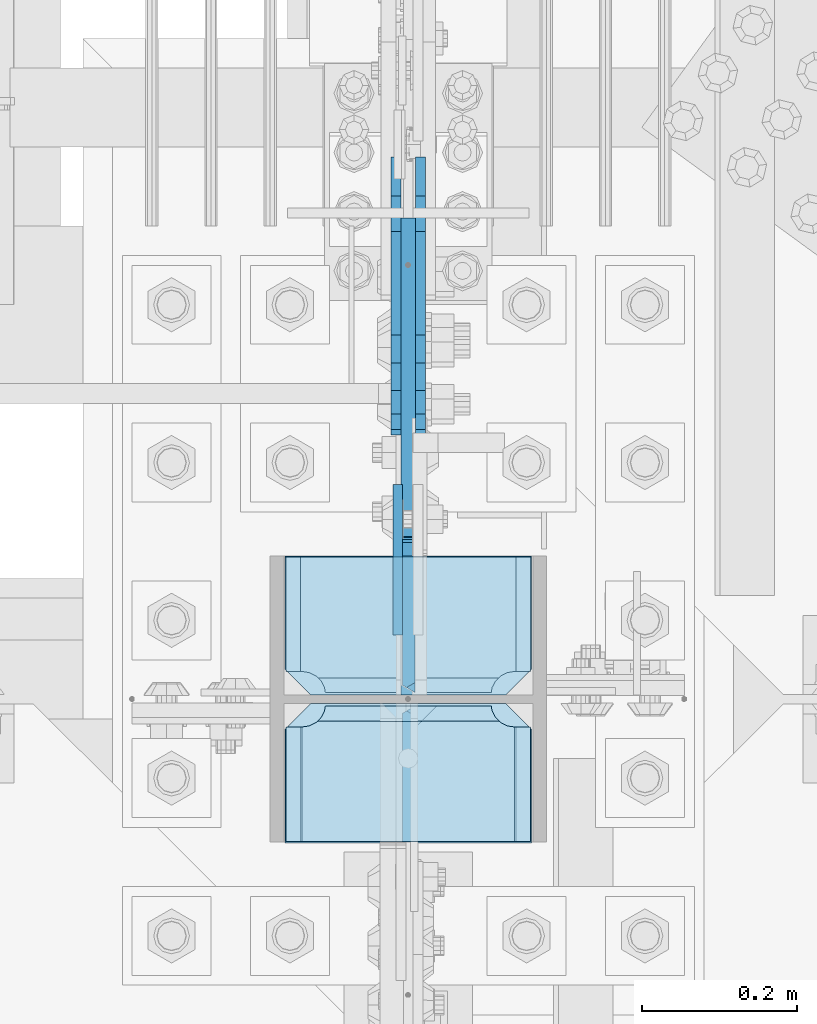
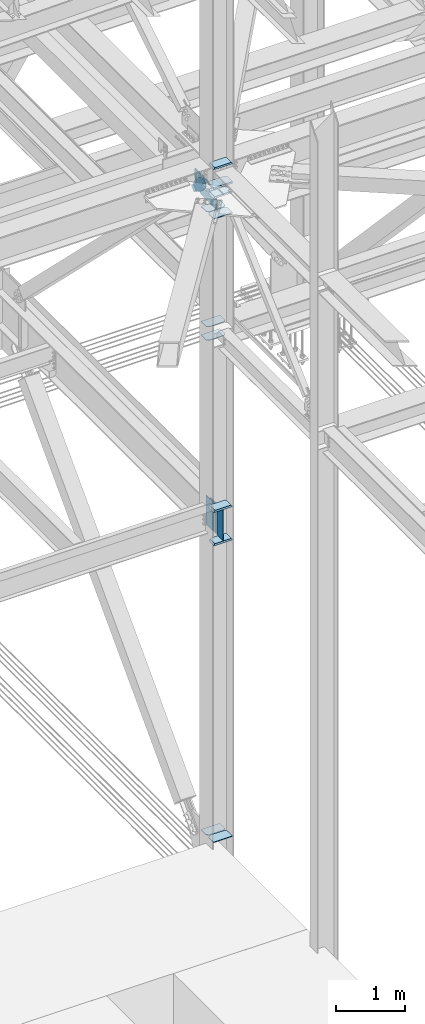
# One storey, part 3513 of 3843: 19 plates, 3 elements without a shape of their own.
"""IFC2X3 building model written with IfcOpenShell, lengths in millimetres."""

from ifc_helpers import new_model, si_unit, frame, origin_with_axes, place, context, subcontext, project, spatial, faceted_brep, material, type_object, element, aggregate, save


model = new_model("IFC2X3")

# Units and contexts
model_context = context("Model", 3, precision=1e-05, world=origin_with_axes())
body_context = subcontext(model_context, "Body", "Model", "MODEL_VIEW")
ifc_project = project(units=[si_unit("LENGTHUNIT", "METRE", prefix="MILLI"), si_unit("AREAUNIT", "SQUARE_METRE"), si_unit("VOLUMEUNIT", "CUBIC_METRE"), si_unit("MASSUNIT", "GRAM", prefix="KILO"), si_unit("TIMEUNIT", "SECOND"), si_unit("PLANEANGLEUNIT", "RADIAN"), si_unit("SOLIDANGLEUNIT", "STERADIAN"), si_unit("THERMODYNAMICTEMPERATUREUNIT", "DEGREE_CELSIUS"), si_unit("LUMINOUSINTENSITYUNIT", "LUMEN")], contexts=[model_context])

# Site, building, storey
site_placement = place(None, origin_with_axes())
site = spatial("IfcSite", under=ifc_project, at=site_placement, CompositionType="ELEMENT")
building_placement = place(site_placement, origin_with_axes())
building = spatial("IfcBuilding", under=site, at=building_placement, Name="Undefined", CompositionType="ELEMENT")
storey_placement = place(building_placement, origin_with_axes())
storey = spatial("IfcBuildingStorey", under=building, at=storey_placement, Name="Undefined", CompositionType="ELEMENT", Elevation=0.0)

# Assembly, plates
assembly_1_placement = place(storey_placement, origin_with_axes())
assembly_1 = element("IfcElementAssembly", 1, at=assembly_1_placement, inside=storey, Name="COLUMN", AssemblyPlace="NOTDEFINED", PredefinedType="RIGID_FRAME")
ifc_material_1 = material(Name="STEEL/A572-50")
plate_type_1 = type_object("IfcPlateType", PredefinedType="NOTDEFINED")
plate_1_placement = place(assembly_1_placement, frame((76854.05, 92220.25625, 39308.0875), z_axis=(1.0, 0.0, 0.0), x_axis=(0.0, 1.0, 0.0)))
plate_1 = element("IfcPlate", 2, at=plate_1_placement, type_object=plate_type_1, material=ifc_material_1, Name="PLATE", context=body_context, shape_type="Brep", body=[
    faceted_brep([(0.0, -4.76249999999709, 33.3375015258789), (0.0, -4.76249999999709, 284.162498474121), (0.0, 4.76249999999709, 284.162498474121), (0.0, 4.76249999999709, 33.3375015258789), (33.3375015258789, -4.76249999999709, 317.5), (33.3375015258789, 4.76249999999709, 317.5), (177.800003051758, -4.76249999999709, 317.5), (177.800003051758, 4.76249999999709, 317.5), (177.800000000003, -4.76249999999709, -1.45519152283669e-11), (177.800000000003, 4.76249999999709, -1.45519152283669e-11), (33.3375015258789, -4.76249999999709, 0.0), (33.3375015258789, 4.76249999999709, 0.0)], [[[0, 1, 2, 3]], [[1, 4, 5, 2]], [[4, 6, 7, 5]], [[6, 8, 9, 7]], [[8, 10, 11, 9]], [[10, 0, 3, 11]], [[5, 7, 9, 11, 3, 2]], [[10, 8, 6, 4, 1, 0]]]),
])
plate_2_placement = place(assembly_1_placement, frame((76854.05, 92220.25625, 39546.2125), z_axis=(1.0, 0.0, 0.0), x_axis=(0.0, 1.0, 0.0)))
plate_2 = element("IfcPlate", 3, at=plate_2_placement, type_object=plate_type_1, material=ifc_material_1, Name="PLATE", context=body_context, shape_type="Brep", body=[
    faceted_brep([(0.0, -4.76249999999709, 33.3375015258789), (0.0, -4.76249999999709, 284.162498474121), (0.0, 4.76249999999709, 284.162498474121), (0.0, 4.76249999999709, 33.3375015258789), (33.3375015258789, -4.76249999999709, 317.5), (33.3375015258789, 4.76249999999709, 317.5), (177.800003051758, -4.76249999999709, 317.5), (177.800003051758, 4.76249999999709, 317.5), (177.800000000003, -4.76249999999709, -1.45519152283669e-11), (177.800000000003, 4.76249999999709, -1.45519152283669e-11), (33.3375015258789, -4.76249999999709, 0.0), (33.3375015258789, 4.76249999999709, 0.0)], [[[0, 1, 2, 3]], [[1, 4, 5, 2]], [[4, 6, 7, 5]], [[6, 8, 9, 7]], [[8, 10, 11, 9]], [[10, 0, 3, 11]], [[5, 7, 9, 11, 3, 2]], [[10, 8, 6, 4, 1, 0]]]),
])
plate_type_2 = type_object("IfcPlateType", PredefinedType="NOTDEFINED")
plate_3_placement = place(assembly_1_placement, frame((77171.55, 92220.25625, 41570.3512645812), z_axis=(0.0, 1.0, 0.0), x_axis=(-1.0, 0.0, 0.0)))
plate_3 = element("IfcPlate", 4, at=plate_3_placement, type_object=plate_type_2, material=ifc_material_1, Name="CB_COL", context=body_context, shape_type="Brep", body=[
    faceted_brep([(0.0, -6.34999999999854, 33.3375015258789), (0.0, -6.34999999999854, 178.59375), (0.0, 6.34999999999854, 178.59375), (0.0, 6.34999999999854, 33.3375015258789), (317.499999999985, -6.34999999999854, 178.59375), (317.499999999985, 6.34999999999854, 178.59375), (317.499999999985, -6.34999999999854, 33.3375015258789), (317.499999999985, 6.34999999999854, 33.3375015258789), (284.162498474107, -6.34999999999854, 0.0), (284.162498474107, 6.34999999999854, 0.0), (33.3375015258789, -6.34999999999854, 0.0), (33.3375015258789, 6.34999999999854, 0.0)], [[[0, 1, 2, 3]], [[1, 4, 5, 2]], [[4, 6, 7, 5]], [[6, 8, 9, 7]], [[8, 10, 11, 9]], [[10, 0, 3, 11]], [[5, 7, 9, 11, 3, 2]], [[10, 8, 6, 4, 1, 0]]]),
])
plate_4_placement = place(assembly_1_placement, frame((77171.55, 92209.14375, 41570.3512645812), z_axis=(0.0, -1.0, 0.0), x_axis=(-1.0, 0.0, 0.0)))
plate_4 = element("IfcPlate", 5, at=plate_4_placement, type_object=plate_type_2, material=ifc_material_1, Name="CB_COL", context=body_context, shape_type="Brep", body=[
    faceted_brep([(0.0, -6.34999999999854, 33.3375015258789), (0.0, -6.34999999999854, 178.59375), (0.0, 6.34999999999854, 178.59375), (0.0, 6.34999999999854, 33.3375015258789), (317.499999999985, -6.34999999999854, 178.59375), (317.499999999985, 6.34999999999854, 178.59375), (317.499999999985, -6.34999999999854, 33.3375015258789), (317.499999999985, 6.34999999999854, 33.3375015258789), (284.162498474107, -6.34999999999854, 0.0), (284.162498474107, 6.34999999999854, 0.0), (33.3375015258789, -6.34999999999854, 0.0), (33.3375015258789, 6.34999999999854, 0.0)], [[[0, 1, 2, 3]], [[1, 4, 5, 2]], [[4, 6, 7, 5]], [[6, 8, 9, 7]], [[8, 10, 11, 9]], [[10, 0, 3, 11]], [[5, 7, 9, 11, 3, 2]], [[10, 8, 6, 4, 1, 0]]]),
])
plate_5_placement = place(assembly_1_placement, frame((77171.55, 92220.25625, 30598.6080263682), z_axis=(0.0, 1.0, 0.0), x_axis=(-1.0, 0.0, 0.0)))
plate_5 = element("IfcPlate", 6, at=plate_5_placement, type_object=plate_type_2, material=ifc_material_1, Name="CB_COL", context=body_context, shape_type="Brep", body=[
    faceted_brep([(0.0, -6.34999999999854, 33.3375015258789), (0.0, -6.34999999999854, 178.59375), (0.0, 6.34999999999854, 178.59375), (0.0, 6.34999999999854, 33.3375015258789), (317.499999999985, -6.34999999999854, 178.59375), (317.499999999985, 6.34999999999854, 178.59375), (317.499999999985, -6.34999999999854, 33.3375015258789), (317.499999999985, 6.34999999999854, 33.3375015258789), (284.162498474107, -6.34999999999854, 0.0), (284.162498474107, 6.34999999999854, 0.0), (33.3375015258789, -6.34999999999854, 0.0), (33.3375015258789, 6.34999999999854, 0.0)], [[[0, 1, 2, 3]], [[1, 4, 5, 2]], [[4, 6, 7, 5]], [[6, 8, 9, 7]], [[8, 10, 11, 9]], [[10, 0, 3, 11]], [[5, 7, 9, 11, 3, 2]], [[10, 8, 6, 4, 1, 0]]]),
])
plate_6_placement = place(assembly_1_placement, frame((77171.55, 92209.14375, 30598.6080263682), z_axis=(0.0, -1.0, 0.0), x_axis=(-1.0, 0.0, 0.0)))
plate_6 = element("IfcPlate", 7, at=plate_6_placement, type_object=plate_type_2, material=ifc_material_1, Name="CB_COL", context=body_context, shape_type="Brep", body=[
    faceted_brep([(0.0, -6.34999999999854, 33.3375015258789), (0.0, -6.34999999999854, 178.59375), (0.0, 6.34999999999854, 178.59375), (0.0, 6.34999999999854, 33.3375015258789), (317.499999999985, -6.34999999999854, 178.59375), (317.499999999985, 6.34999999999854, 178.59375), (317.499999999985, -6.34999999999854, 33.3375015258789), (317.499999999985, 6.34999999999854, 33.3375015258789), (284.162498474107, -6.34999999999854, 0.0), (284.162498474107, 6.34999999999854, 0.0), (33.3375015258789, -6.34999999999854, 0.0), (33.3375015258789, 6.34999999999854, 0.0)], [[[0, 1, 2, 3]], [[1, 4, 5, 2]], [[4, 6, 7, 5]], [[6, 8, 9, 7]], [[8, 10, 11, 9]], [[10, 0, 3, 11]], [[5, 7, 9, 11, 3, 2]], [[10, 8, 6, 4, 1, 0]]]),
])
plate_type_3 = type_object("IfcPlateType", PredefinedType="NOTDEFINED")
plate_7_placement = place(assembly_1_placement, frame((77173.1375, 92209.14375, 42452.925), z_axis=(-1.0, 0.0, 0.0), x_axis=(0.0, -1.0, 0.0)))
plate_7 = element("IfcPlate", 8, at=plate_7_placement, type_object=plate_type_3, material=ifc_material_1, Name="PLATE", context=body_context, shape_type="Brep", body=[
    faceted_brep([(17.7290728964945, 9.33436282556067, 272.460526505907), (21.5053709990898, 15.875, 276.236824608495), (21.5053709990898, 15.875, 44.4381753915077), (17.7290728964945, 9.33436282556067, 48.2144734940957), (9.32072521071677, -5.22909322453052, 52.4987406282016), (3.174499952318, -15.875, 53.472207075858), (3.174499952318, -15.875, 267.202792924145), (9.32072521071314, -5.22909322453052, 268.176259371801), (30.1625003814697, 15.875, 299.168629000924), (30.1625003814697, -15.875, 317.499500047692), (177.799999999999, -15.875, 317.499500047692), (177.799999999999, 15.875, 299.168629000924), (177.799999999999, 15.875, 21.5053709990898), (177.799999999999, -15.875, 3.17449995232164), (30.1625003814697, -15.875, 3.17449995232164), (30.1625003814697, 15.875, 21.5053709990898), (9.32072521071314, -15.875, 268.176259371801), (17.7290728964945, -15.875, 272.460526505907), (24.401975401448, -15.875, 279.133429010864), (24.401975401448, 15.875, 279.133429010864), (28.6862425355503, -15.875, 287.541776696642), (28.6862425355503, 15.875, 287.541776696642), (30.1625003814697, -15.875, 296.862501907352), (30.1625003814697, 15.875, 296.862501907352), (30.1625003814697, -15.875, 23.8124980926514), (30.1625003814697, 15.875, 23.8124980926514), (28.6862425355503, -15.875, 33.1332233033609), (28.6862425355503, 15.875, 33.1332233033609), (24.401975401448, -15.875, 41.5415709891386), (24.401975401448, 15.875, 41.5415709891386), (17.7290728964945, -15.875, 48.2144734940957), (9.32072521071677, -15.875, 52.4987406282016)], [[[0, 1, 2, 3, 4, 5, 6, 7]], [[8, 9, 10, 11]], [[12, 13, 14, 15]], [[16, 7, 6]], [[16, 17, 0, 7]], [[17, 18, 19, 1, 0]], [[18, 20, 21, 19]], [[20, 22, 23, 21]], [[23, 22, 9, 8]], [[13, 12, 11, 10]], [[24, 25, 15, 14]], [[24, 26, 27, 25]], [[26, 28, 29, 27]], [[29, 28, 30, 3, 2]], [[30, 31, 4, 3]], [[31, 5, 4]], [[19, 21, 23, 8, 11, 12, 15, 25, 27, 29, 2, 1]], [[31, 30, 28, 26, 24, 14, 13, 10, 9, 22, 20, 18, 17, 16, 6, 5]]]),
])
plate_8_placement = place(assembly_1_placement, frame((77173.1375, 92398.05625, 41941.75), z_axis=(-1.0, 0.0, 0.0), x_axis=(0.0, -1.0, 0.0)))
plate_8 = element("IfcPlate", 9, at=plate_8_placement, type_object=plate_type_3, material=ifc_material_1, Name="PLATE", context=body_context, shape_type="Brep", body=[
    faceted_brep([(160.070927103505, 9.33329077896633, 48.2144734940957), (156.294129000915, 15.875, 44.437675391513), (156.294129000915, 15.875, 276.23732460849), (160.070927103505, 9.33329077896633, 272.460526505907), (168.479274789282, -5.23062396988826, 268.176259371801), (174.625000047687, -15.875, 267.202872116366), (174.625000047687, -15.875, 53.4721278836369), (168.479274789282, -5.23062396988826, 52.4987406282016), (147.63749961853, 15.875, 21.5053709990898), (147.63749961853, -15.875, 3.17449995232164), (0.0, -15.875, 3.17449995232164), (0.0, 15.875, 21.5053709990898), (0.0, 15.875, 299.168629000924), (0.0, -15.875, 317.499500047692), (147.63749961853, -15.875, 317.499500047692), (147.63749961853, 15.875, 299.168629000924), (147.63749961853, -15.875, 296.862501907352), (147.63749961853, 15.875, 296.862501907352), (149.113757464445, -15.875, 287.541776696642), (149.113757464445, 15.875, 287.541776696642), (153.398024598548, -15.875, 279.133429010864), (153.398024598548, 15.875, 279.133429010864), (160.070927103505, -15.875, 272.460526505907), (168.479274789282, -15.875, 268.176259371801), (168.479274789282, -15.875, 52.4987406282016), (160.070927103505, -15.875, 48.2144734940957), (153.398024598548, -15.875, 41.5415709891386), (153.398024598548, 15.875, 41.5415709891386), (149.113757464449, -15.875, 33.1332233033609), (149.113757464449, 15.875, 33.1332233033609), (147.63749961853, -15.875, 23.8124980926514), (147.63749961853, 15.875, 23.8124980926514)], [[[0, 1, 2, 3, 4, 5, 6, 7]], [[8, 9, 10, 11]], [[12, 13, 14, 15]], [[13, 12, 11, 10]], [[16, 17, 15, 14]], [[16, 18, 19, 17]], [[18, 20, 21, 19]], [[21, 20, 22, 3, 2]], [[22, 23, 4, 3]], [[23, 5, 4]], [[24, 7, 6]], [[24, 25, 0, 7]], [[25, 26, 27, 1, 0]], [[26, 28, 29, 27]], [[28, 30, 31, 29]], [[31, 30, 9, 8]], [[27, 29, 31, 8, 11, 12, 15, 17, 19, 21, 2, 1]], [[9, 30, 28, 26, 25, 24, 6, 5, 23, 22, 20, 18, 16, 14, 13, 10]]]),
])
plate_type_4 = type_object("IfcPlateType", PredefinedType="NOTDEFINED")
plate_9_placement = place(assembly_1_placement, frame((77013.59375, 92220.25625, 35867.9749999989), z_axis=(0.0, 0.707106781186548, 0.707106781186548), x_axis=(5.70000238222118e-08, 0.707106781186546, -0.707106781186546)))
plate_9 = element("IfcPlate", 10, at=plate_9_placement, type_object=plate_type_4, material=ifc_material_1, Name="PLATE", context=body_context, shape_type="Brep", body=[
    faceted_brep([(-359.718745869817, 7.9375, 377.17075708491), (13.470384184775, 7.9375, 3.98162703046546), (13.4703841731916, 3.06102272879798, -7.27595761418343e-12), (4.49012799309094, -7.9375, 7.27595761418343e-12), (-363.700372896477, -7.9375, 368.190500888973), (-363.70037289607, 3.06102271977579, 377.17075708491), (131.029230272985, 7.9375, 121.540473118737), (137.510171884061, -7.9375, 115.059531507664), (22.4506403026729, -7.93750001103617, 0.0), (-363.700372895662, -7.9375, 386.151013281225), (-248.640841376706, -7.9375, 501.210544800197), (-242.159899765786, 7.9374999999709, 494.729603188942), (10.6640539982182, 7.9375, 241.905649412118), (10.6640539982182, -7.9375, 241.905649412118), (-222.822604861809, 7.9375, 475.392308283961), (-222.822604861809, -7.9375, 475.392308283961)], [[[0, 1, 2, 3, 4, 5]], [[6, 7, 8, 2, 1]], [[9, 10, 11, 0, 5]], [[8, 3, 2]], [[12, 13, 7, 6]], [[14, 15, 13, 12]], [[15, 14, 11, 10]], [[4, 3, 8, 7, 13, 15, 10, 9]], [[9, 5, 4]], [[11, 14, 12, 6, 1, 0]]]),
])
plate_10_placement = place(assembly_1_placement, frame((77013.59375, 92209.1437500001, 35848.925), z_axis=(0.0, 0.0, 1.0), x_axis=(0.0, -1.0, 0.0)))
plate_10 = element("IfcPlate", 11, at=plate_10_placement, type_object=plate_type_4, material=ifc_material_1, Name="PLATE", context=body_context, shape_type="Brep", body=[
    faceted_brep([(3.17499995227263, 7.9375, 536.575000715195), (3.17499995227263, 7.9375, 15.8749992847879), (9.52499961845751, -3.06102204987837, 9.52499961860303), (12.340435475664, -7.9375, 12.3404354758022), (12.340435475664, -7.9375, 540.109564525905), (9.52499961933063, -3.06102205136267, 542.925000382245), (15.8749992846424, 7.9375, 3.17499995241815), (178.593746948245, 7.9375, 3.17499995241815), (178.593746948245, -7.9375, 12.3404354758022), (178.593746948245, -7.9375, 540.109564525905), (178.593746948245, 7.9375000000291, 549.275000049296), (15.8749992863741, 7.9375, 549.275000049296)], [[[0, 1, 2, 3, 4, 5]], [[6, 7, 8, 3, 2]], [[9, 10, 11, 5, 4]], [[6, 2, 1]], [[10, 9, 8, 7]], [[8, 9, 4, 3]], [[11, 0, 5]], [[7, 6, 1, 0, 11, 10]]]),
])
plate_type_5 = type_object("IfcPlateType", PredefinedType="NOTDEFINED")
plate_11_placement = place(assembly_1_placement, frame((76999.30625, 92490.9249995883, 36382.325), z_axis=(0.0, 0.0, -1.0), x_axis=(0.0, -1.0, 0.0)))
plate_11 = element("IfcPlate", 12, at=plate_11_placement, type_object=plate_type_5, material=ifc_material_1, Name="PLATE", context=body_context, shape_type="Brep", body=[
    faceted_brep([(0.0, -6.3499999046162, 0.0), (1.08921085484326e-06, -6.35000000000582, 514.349998644451), (1.08921085484326e-06, 6.35000000000582, 514.349998644451), (7.27595761418343e-12, 6.3499999046162, 0.0), (193.675001089199, -6.35000000000582, 514.349998644284), (193.675001089199, 6.35000000000582, 514.349998644284), (193.674999999996, -6.35000000000582, 0.0), (193.674999999996, 6.35000000000582, 0.0)], [[[0, 1, 2, 3]], [[1, 4, 5, 2]], [[4, 6, 7, 5]], [[6, 0, 3, 7]], [[5, 7, 3, 2]], [[6, 4, 1, 0]]]),
])
plate_type_6 = type_object("IfcPlateType", PredefinedType="NOTDEFINED")
plate_12_placement = place(assembly_1_placement, frame((77019.15, 92031.34375, 41941.7500000004), z_axis=(1.0, 0.0, 0.0), x_axis=(0.0, 1.0, 0.0)))
plate_12 = element("IfcPlate", 13, at=plate_12_placement, type_object=plate_type_6, material=ifc_material_1, Name="STIFFENER", context=body_context, shape_type="Brep", body=[
    faceted_brep([(0.0, 15.875, 132.482129000913), (0.0, -15.875, 150.813000047681), (147.637499618533, -15.875, 150.813000047681), (147.637499618533, 15.875, 132.482129000913), (156.294379000916, 15.875, 109.549574608493), (160.070927103516, 9.33382680899376, 105.773026505907), (168.479274789293, -5.22985859066102, 101.488759371801), (174.625250047684, -15.875, 100.515332520255), (174.625250047684, -15.875, 30.1627515735599), (156.294379000916, 15.875, 11.8318805267918), (0.0, 15.875, 0.0), (0.0, -15.875, 0.0), (147.637499618533, -15.875, 130.175001907352), (147.637499618533, 15.875, 130.175001907352), (149.113757464453, -15.875, 120.854276696642), (149.113757464453, 15.875, 120.854276696642), (153.398024598559, -15.875, 112.445929010864), (153.398024598559, 15.875, 112.445929010864), (160.070927103516, -15.875, 105.773026505907), (168.479274789293, -15.875, 101.488759371801), (144.462498474124, -15.875, 0.0), (144.462498474124, 15.875, 0.0)], [[[0, 1, 2, 3]], [[4, 5, 6, 7, 8, 9]], [[10, 11, 1, 0]], [[12, 13, 3, 2]], [[12, 14, 15, 13]], [[14, 16, 17, 15]], [[17, 16, 18, 5, 4]], [[18, 19, 6, 5]], [[19, 7, 6]], [[20, 21, 9, 8]], [[20, 11, 10, 21]], [[13, 15, 17, 4, 9, 21, 10, 0, 3]], [[20, 8, 7, 19, 18, 16, 14, 12, 2, 1, 11]]]),
])
plate_13_placement = place(assembly_1_placement, frame((77006.45, 92031.34375, 41941.7500000004), z_axis=(-1.0, 0.0, 0.0), x_axis=(0.0, 1.0, 0.0)))
plate_13 = element("IfcPlate", 14, at=plate_13_placement, type_object=plate_type_6, material=ifc_material_1, Name="STIFFENER", context=body_context, shape_type="Brep", body=[
    faceted_brep([(147.637499618533, -15.875, 132.481129000909), (147.637499618533, 15.875, 150.812000047677), (0.0, 15.875, 150.812000047677), (0.0, -15.875, 132.481129000909), (160.070927103516, -9.33382680899376, 105.773026505907), (156.294379000916, -15.875, 109.549574608493), (156.294379000916, -15.875, 11.8318805267918), (174.625250047684, 15.875, 30.1627515735599), (174.625250047684, 15.875, 100.515332520255), (168.479274789293, 5.22985859066102, 101.488759371801), (0.0, 15.875, 0.0), (0.0, -15.875, 0.0), (147.637499618533, -15.875, 130.175001907352), (147.637499618533, 15.875, 130.175001907352), (149.113757464453, -15.875, 120.854276696642), (149.113757464453, 15.875, 120.854276696642), (153.398024598559, -15.875, 112.445929010864), (153.398024598559, 15.875, 112.445929010864), (160.070927103516, 15.875, 105.773026505907), (168.479274789293, 15.875, 101.488759371801), (144.462498474124, -15.875, 0.0), (144.462498474124, 15.875, 0.0)], [[[0, 1, 2, 3]], [[4, 5, 6, 7, 8, 9]], [[10, 11, 3, 2]], [[12, 13, 1, 0]], [[12, 14, 15, 13]], [[14, 16, 17, 15]], [[18, 17, 16, 5, 4]], [[19, 18, 4, 9]], [[19, 9, 8]], [[20, 21, 7, 6]], [[20, 11, 10, 21]], [[1, 13, 15, 17, 18, 19, 8, 7, 21, 10, 2]], [[11, 20, 6, 5, 16, 14, 12, 0, 3]]]),
])
plate_type_7 = type_object("IfcPlateType", PredefinedType="NOTDEFINED")
plate_14_placement = place(assembly_1_placement, frame((76854.05, 92029.75625, 42108.4375000006), z_axis=(1.0, 0.0, 0.0), x_axis=(0.0, 1.0, 0.0)))
plate_14 = element("IfcPlate", 15, at=plate_14_placement, type_object=plate_type_7, material=ifc_material_1, Name="PLATE", context=body_context, shape_type="Brep", body=[
    faceted_brep([(0.0, -15.875, 0.0), (0.0, -15.875, 317.5), (0.0, 15.875, 317.5), (0.0, 15.875, 0.0), (146.049998474133, -15.875, 317.5), (146.049998474133, 15.875, 317.5), (179.387500000012, -15.875, 284.162498474121), (179.387500000012, 15.875, 284.162498474121), (179.387500000012, -15.875, 33.3375015258789), (179.387500000012, 15.875, 33.3375015258789), (146.049998474133, -15.875, 0.0), (146.049998474133, 15.875, 0.0)], [[[0, 1, 2, 3]], [[1, 4, 5, 2]], [[4, 6, 7, 5]], [[6, 8, 9, 7]], [[8, 10, 11, 9]], [[10, 0, 3, 11]], [[5, 7, 9, 11, 3, 2]], [[10, 8, 6, 4, 1, 0]]]),
])
plate_type_8 = type_object("IfcPlateType", PredefinedType="NOTDEFINED")
plate_15_placement = place(assembly_1_placement, frame((77173.1375, 92209.14375, 35831.4625), z_axis=(-1.0, 0.0, 0.0), x_axis=(0.0, -1.0, 0.0)))
plate_15 = element("IfcPlate", 16, at=plate_15_placement, type_object=plate_type_8, material=ifc_material_1, Name="PLATE", context=body_context, shape_type="Brep", body=[
    faceted_brep([(17.7290728964872, 7.74676058471232, 272.460514298873), (23.3384576632816, 17.4625000000015, 278.069899065653), (23.3384576632816, 17.4625000000015, 42.6050887273159), (17.7290728964872, 7.74676058471232, 48.2144734940957), (9.3207252107095, -6.81692481475329, 52.4987406282016), (3.17449995232164, -17.4625000000015, 53.472207075858), (3.17449995232164, -17.4625000000015, 267.202780717111), (9.3207252107095, -6.81692481475329, 268.176247164767), (30.1625003814697, 17.4625000000015, 297.335542336717), (30.1625003814697, -17.4625000000015, 317.499500047677), (177.800000000001, -17.4625000000015, 317.499500047677), (177.800000000001, 17.4625000000015, 297.335542336717), (177.800000000001, 17.4625000000015, 23.338457663267), (177.800000000001, -17.4625000000015, 3.17449995230709), (30.1625003814697, -17.4625000000015, 3.17449995230709), (30.1625003814697, 17.4625000000015, 23.338457663267), (9.3207252107095, -17.4625000000015, 268.176247164767), (17.7290728964872, -17.4625000000015, 272.460514298873), (24.4019754014444, -17.4625000000015, 279.133416803816), (24.4019754014444, 17.4625000000015, 279.133416803816), (28.6862425355503, -17.4625000000015, 287.541764489608), (28.6862425355503, 17.4625000000015, 287.541764489608), (30.1625003814697, -17.4625000000015, 296.862489700317), (30.1625003814697, 17.4625000000015, 296.862489700317), (30.1625003814697, -17.4625000000015, 23.8124980926514), (30.1625003814697, 17.4625000000015, 23.8124980926514), (28.6862425355503, -17.4625000000015, 33.1332233033609), (28.6862425355503, 17.4625000000015, 33.1332233033609), (24.4019754014444, -17.4625000000015, 41.5415709891386), (24.4019754014444, 17.4625000000015, 41.5415709891386), (17.7290728964872, -17.4625000000015, 48.2144734940957), (9.3207252107095, -17.4625000000015, 52.4987406282016)], [[[0, 1, 2, 3, 4, 5, 6, 7]], [[8, 9, 10, 11]], [[12, 13, 14, 15]], [[16, 7, 6]], [[16, 17, 0, 7]], [[17, 18, 19, 1, 0]], [[18, 20, 21, 19]], [[20, 22, 23, 21]], [[23, 22, 9, 8]], [[11, 10, 13, 12]], [[24, 25, 15, 14]], [[24, 26, 27, 25]], [[26, 28, 29, 27]], [[29, 28, 30, 3, 2]], [[30, 31, 4, 3]], [[31, 5, 4]], [[19, 21, 23, 8, 11, 12, 15, 25, 27, 29, 2, 1]], [[31, 30, 28, 26, 24, 14, 13, 10, 9, 22, 20, 18, 17, 16, 6, 5]]]),
])
plate_16_placement = place(assembly_1_placement, frame((77173.1375, 92209.14375, 36418.8375), z_axis=(-1.0, 0.0, 0.0), x_axis=(0.0, -1.0, 0.0)))
plate_16 = element("IfcPlate", 17, at=plate_16_placement, type_object=plate_type_8, material=ifc_material_1, Name="PLATE", context=body_context, shape_type="Brep", body=[
    faceted_brep([(17.7290728964872, 7.74676058471232, 272.460514298873), (23.3384576632816, 17.4625000000015, 278.069899065653), (23.3384576632816, 17.4625000000015, 42.6050887273159), (17.7290728964872, 7.74676058471232, 48.2144734940957), (9.3207252107095, -6.81692481475329, 52.4987406282016), (3.17449995232164, -17.4625000000015, 53.472207075858), (3.17449995232164, -17.4625000000015, 267.202780717111), (9.3207252107095, -6.81692481475329, 268.176247164767), (30.1625003814697, 17.4625000000015, 297.335542336717), (30.1625003814697, -17.4625000000015, 317.499500047677), (177.800000000001, -17.4625000000015, 317.499500047677), (177.800000000001, 17.4625000000015, 297.335542336717), (177.800000000001, 17.4625000000015, 23.338457663267), (177.800000000001, -17.4625000000015, 3.17449995230709), (30.1625003814697, -17.4625000000015, 3.17449995230709), (30.1625003814697, 17.4625000000015, 23.338457663267), (9.3207252107095, -17.4625000000015, 268.176247164767), (17.7290728964872, -17.4625000000015, 272.460514298873), (24.4019754014444, -17.4625000000015, 279.133416803816), (24.4019754014444, 17.4625000000015, 279.133416803816), (28.6862425355503, -17.4625000000015, 287.541764489608), (28.6862425355503, 17.4625000000015, 287.541764489608), (30.1625003814697, -17.4625000000015, 296.862489700317), (30.1625003814697, 17.4625000000015, 296.862489700317), (30.1625003814697, -17.4625000000015, 23.8124980926514), (30.1625003814697, 17.4625000000015, 23.8124980926514), (28.6862425355503, -17.4625000000015, 33.1332233033609), (28.6862425355503, 17.4625000000015, 33.1332233033609), (24.4019754014444, -17.4625000000015, 41.5415709891386), (24.4019754014444, 17.4625000000015, 41.5415709891386), (17.7290728964872, -17.4625000000015, 48.2144734940957), (9.3207252107095, -17.4625000000015, 52.4987406282016)], [[[0, 1, 2, 3, 4, 5, 6, 7]], [[8, 9, 10, 11]], [[12, 13, 14, 15]], [[16, 7, 6]], [[16, 17, 0, 7]], [[17, 18, 19, 1, 0]], [[18, 20, 21, 19]], [[20, 22, 23, 21]], [[23, 22, 9, 8]], [[11, 10, 13, 12]], [[24, 25, 15, 14]], [[24, 26, 27, 25]], [[26, 28, 29, 27]], [[29, 28, 30, 3, 2]], [[30, 31, 4, 3]], [[31, 5, 4]], [[19, 21, 23, 8, 11, 12, 15, 25, 27, 29, 2, 1]], [[31, 30, 28, 26, 24, 14, 13, 10, 9, 22, 20, 18, 17, 16, 6, 5]]]),
])
plate_type_9 = type_object("IfcPlateType", PredefinedType="NOTDEFINED")
plate_17_placement = place(assembly_1_placement, frame((77012.8, 92834.7170207929, 41925.875), z_axis=(0.0, 0.0, -1.0), x_axis=(0.0, -1.0, 0.0)))
plate_17 = element("IfcPlate", 18, at=plate_17_placement, type_object=plate_type_9, material=ifc_material_1, Name="CB", context=body_context, shape_type="Brep", body=[
    faceted_brep([(461.267018126659, -9.52499999999418, 25.4000001907334), (461.267018126659, 9.52499999999418, 25.4000001907334), (461.267018126659, 9.52499999999418, 0.0), (461.267018126659, -9.52499999999418, 0.0), (460.300288204075, -9.52499999999418, 30.2600797087798), (460.300288204075, 9.52499999999418, 30.2600797087798), (457.547274303593, -9.52499999999418, 34.3802561769335), (457.547274303593, 9.52499999999418, 34.3802561769335), (453.427097835433, -9.52499999999418, 37.1332700774074), (453.427097835433, 9.52499999999418, 37.1332700774074), (448.567018317393, -9.52499999999418, 38.0999999999985), (448.567018317393, 9.52499999999418, 38.0999999999985), (423.167017935921, -9.52499999999418, 38.0999999999985), (423.167017935921, 9.52499999999418, 38.0999999999985), (418.306938417882, -9.52499999999418, 37.1332700774074), (418.306938417882, 9.52499999999418, 37.1332700774074), (414.186761949721, -9.52499999999418, 34.3802561769335), (414.186761949721, 9.52499999999418, 34.3802561769335), (411.43374804924, -9.52499999999418, 30.2600797087798), (411.43374804924, 9.52499999999418, 30.2600797087798), (410.467018126656, -9.52499999999418, 25.4000001907334), (410.467018126656, 9.52499999999418, 25.4000001907334), (410.467018126656, -9.52499999999418, 0.0), (410.467018126656, 9.52499999999418, 0.0), (0.0, -9.52500000000146, 0.0), (0.0, 9.52500000000146, 0.0), (0.0, -9.52499999999418, 171.486764635461), (0.0, 9.52499999999418, 171.486764635461), (174.807783674798, -9.52499999999418, 349.173735418757), (174.807783674798, 9.52499999999418, 349.173735418757), (595.410768889589, -9.52499999999418, 349.173735418757), (595.410768889589, 9.52499999999418, 349.173735418757), (614.46076812665, -9.52499999999418, 330.123736181697), (614.46076812665, 9.52499999999418, 330.123736181697), (614.46076812665, -9.52499999999418, 19.0500000000102), (614.46076812665, 9.52499999999418, 19.0500000000102), (595.410768126632, 9.52499999999418, 0.0), (595.410768126632, -9.52499999999418, 0.0)], [[[0, 1, 2, 3]], [[4, 5, 1, 0]], [[6, 7, 5, 4]], [[8, 9, 7, 6]], [[10, 11, 9, 8]], [[12, 13, 11, 10]], [[14, 15, 13, 12]], [[16, 17, 15, 14]], [[18, 19, 17, 16]], [[20, 21, 19, 18]], [[22, 23, 21, 20]], [[24, 25, 23, 22]], [[24, 26, 27, 25]], [[26, 28, 29, 27]], [[28, 30, 31, 29]], [[30, 32, 33, 31]], [[33, 32, 34, 35]], [[2, 1, 5, 7, 9, 11, 13, 15, 17, 19, 21, 23, 25, 27, 29, 31, 33, 35, 36]], [[3, 2, 36, 37]], [[32, 30, 28, 26, 24, 22, 20, 18, 16, 14, 12, 10, 8, 6, 4, 0, 3, 37, 34]], [[36, 35, 34, 37]]]),
])
aggregate(assembly_1, [plate_11, plate_9, plate_10, plate_1, plate_2, plate_12, plate_13, plate_14, plate_15, plate_16, plate_7, plate_8, plate_3, plate_4, plate_17, plate_5, plate_6])

# Assembly, plate
assembly_2_placement = place(storey_placement, origin_with_axes())
assembly_2 = element("IfcElementAssembly", 19, at=assembly_2_placement, inside=storey, AssemblyPlace="NOTDEFINED", PredefinedType="RIGID_FRAME")
ifc_material_2 = material(Name="STEEL/A36")
plate_type_10 = type_object("IfcPlateType", PredefinedType="NOTDEFINED")
plate_18_placement = place(assembly_2_placement, frame((76996.925, 92862.9820902874, 41638.2466343326), z_axis=(0.0, -0.701307718956826, -0.712858669956096), x_axis=(0.0, 0.712858669956096, -0.701307718956826)))
plate_18 = element("IfcPlate", 20, at=plate_18_placement, type_object=plate_type_10, material=ifc_material_2, context=body_context, shape_type="Brep", body=[
    faceted_brep([(0.0, -6.3499999046162, 0.0), (-101.600000000049, -6.35000000000582, -37.5700346004523), (-101.600000000049, 6.35000000000582, -37.5700346004523), (7.27595761418343e-12, 6.3499999046162, 0.0), (-245.369242325265, -6.35000000000582, -37.5700346003141), (-245.369242325265, 6.35000000000582, -37.5700346003141), (-281.212328726207, -6.35000000000582, -30.4404014297979), (-281.212328726207, 6.35000000000582, -30.4404014297979), (-311.59863014071, -6.35000000000582, -10.1369239383566), (-311.59863014071, 6.35000000000582, -10.1369239383566), (-331.902107630653, -6.35000000000582, 20.2493774772229), (-331.902107630653, 6.35000000000582, 20.2493774772229), (-339.031740799503, -6.35000000000582, 56.0924669294036), (-339.031740799503, 6.35000000000582, 56.0924669294036), (-331.902107628353, -6.35000000000582, 91.9355533280759), (-331.902107628353, 6.35000000000582, 91.9355533280759), (-311.598630138033, -6.35000000000582, 122.321854740563), (-311.598630138033, 6.35000000000582, 122.321854740563), (-281.212328724767, -6.35000000000582, 142.625332229603), (-281.212328724767, 6.35000000000582, 142.625332229603), (-245.369240796863, -6.35000000000582, 149.754965399145), (-245.369240796863, 6.35000000000582, 149.754965399145), (-101.599999991755, -6.35000000000582, 149.754965398992), (-101.599999991755, 6.35000000000582, 149.754965398992), (4.9622030928731e-09, -6.35000000000582, 112.184930798256), (4.9622030928731e-09, 6.35000000000582, 112.184930798256), (69.8500000038475, -6.35000000000582, 112.184930798168), (69.8500000038475, 6.35000000000582, 112.184930798168), (69.8499999985434, -6.35000000000582, -8.73114913702011e-11), (69.8499999985434, 6.35000000000582, -8.73114913702011e-11)], [[[0, 1, 2, 3]], [[1, 4, 5, 2]], [[4, 6, 7, 5]], [[6, 8, 9, 7]], [[8, 10, 11, 9]], [[10, 12, 13, 11]], [[12, 14, 15, 13]], [[14, 16, 17, 15]], [[16, 18, 19, 17]], [[18, 20, 21, 19]], [[20, 22, 23, 21]], [[22, 24, 25, 23]], [[24, 26, 27, 25]], [[26, 28, 29, 27]], [[28, 0, 3, 29]], [[5, 7, 9, 11, 13, 15, 17, 19, 21, 23, 25, 27, 29, 3, 2]], [[28, 26, 24, 22, 20, 18, 16, 14, 12, 10, 8, 6, 4, 1, 0]]]),
])
aggregate(assembly_2, [plate_18])

assembly_3_placement = place(storey_placement, origin_with_axes())
assembly_3 = element("IfcElementAssembly", 21, at=assembly_3_placement, inside=storey, AssemblyPlace="NOTDEFINED", PredefinedType="RIGID_FRAME")
plate_19_placement = place(assembly_3_placement, frame((77028.675, 92862.9820902874, 41638.2466343326), z_axis=(0.0, -0.701307718956826, -0.712858669956096), x_axis=(0.0, 0.712858669956096, -0.701307718956826)))
plate_19 = element("IfcPlate", 22, at=plate_19_placement, type_object=plate_type_10, material=ifc_material_2, context=body_context, shape_type="Brep", body=[
    faceted_brep([(0.0, -6.3499999046162, 0.0), (-101.600000000049, -6.35000000000582, -37.5700346004523), (-101.600000000049, 6.35000000000582, -37.5700346004523), (7.27595761418343e-12, 6.3499999046162, 0.0), (-245.369242325265, -6.35000000000582, -37.5700346003141), (-245.369242325265, 6.35000000000582, -37.5700346003141), (-281.212328726207, -6.35000000000582, -30.4404014297979), (-281.212328726207, 6.35000000000582, -30.4404014297979), (-311.59863014071, -6.35000000000582, -10.1369239383566), (-311.59863014071, 6.35000000000582, -10.1369239383566), (-331.902107630653, -6.35000000000582, 20.2493774772229), (-331.902107630653, 6.35000000000582, 20.2493774772229), (-339.031740799503, -6.35000000000582, 56.0924669294036), (-339.031740799503, 6.35000000000582, 56.0924669294036), (-331.902107628353, -6.35000000000582, 91.9355533280759), (-331.902107628353, 6.35000000000582, 91.9355533280759), (-311.598630138033, -6.35000000000582, 122.321854740563), (-311.598630138033, 6.35000000000582, 122.321854740563), (-281.212328724767, -6.35000000000582, 142.625332229603), (-281.212328724767, 6.35000000000582, 142.625332229603), (-245.369240796863, -6.35000000000582, 149.754965399145), (-245.369240796863, 6.35000000000582, 149.754965399145), (-101.599999991755, -6.35000000000582, 149.754965398992), (-101.599999991755, 6.35000000000582, 149.754965398992), (4.9622030928731e-09, -6.35000000000582, 112.184930798256), (4.9622030928731e-09, 6.35000000000582, 112.184930798256), (69.8500000038475, -6.35000000000582, 112.184930798168), (69.8500000038475, 6.35000000000582, 112.184930798168), (69.8499999985434, -6.35000000000582, -8.73114913702011e-11), (69.8499999985434, 6.35000000000582, -8.73114913702011e-11)], [[[0, 1, 2, 3]], [[1, 4, 5, 2]], [[4, 6, 7, 5]], [[6, 8, 9, 7]], [[8, 10, 11, 9]], [[10, 12, 13, 11]], [[12, 14, 15, 13]], [[14, 16, 17, 15]], [[16, 18, 19, 17]], [[18, 20, 21, 19]], [[20, 22, 23, 21]], [[22, 24, 25, 23]], [[24, 26, 27, 25]], [[26, 28, 29, 27]], [[28, 0, 3, 29]], [[5, 7, 9, 11, 13, 15, 17, 19, 21, 23, 25, 27, 29, 3, 2]], [[28, 26, 24, 22, 20, 18, 16, 14, 12, 10, 8, 6, 4, 1, 0]]]),
])
aggregate(assembly_3, [plate_19])

save(model, "model.ifc")
